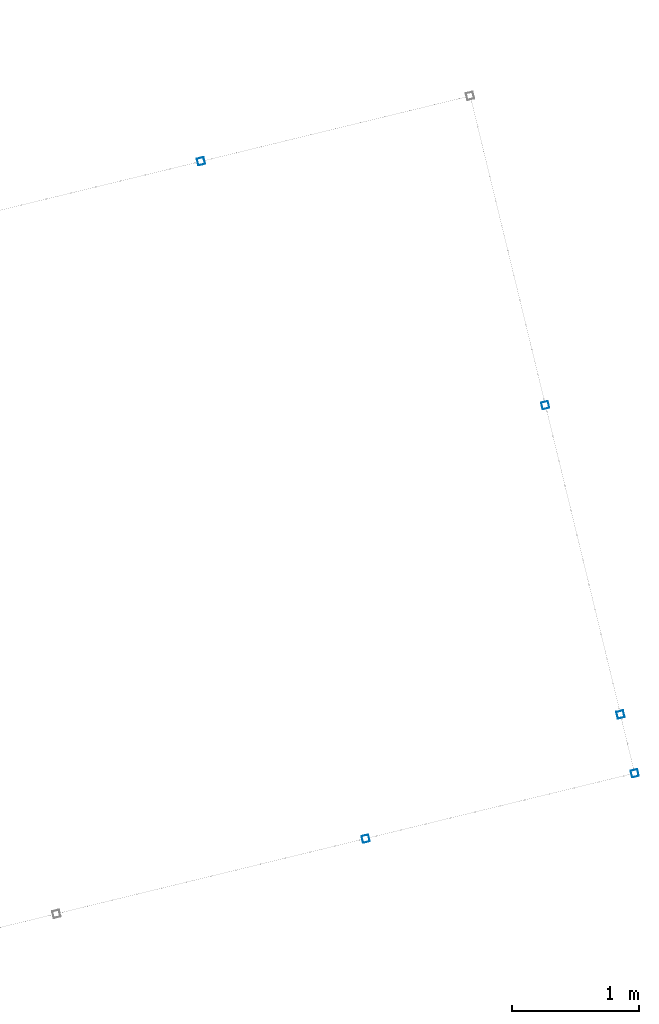
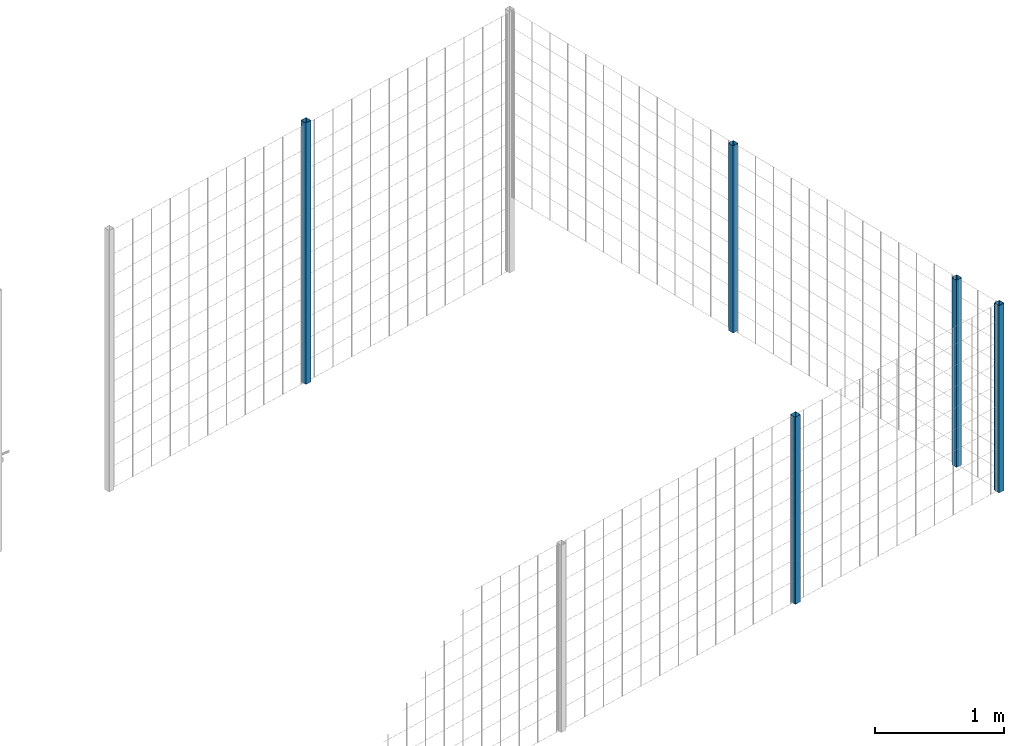
# One storey, part 4 of 10: 5 beams.
"""IFC2X3 building model written with IfcOpenShell, lengths in millimetres."""

from ifc_helpers import new_model, entity, si_unit, converted_unit, derived_unit, direction, frame, frame_2d, origin, place, context, subcontext, project, spatial, polyline, circle_curve, parameter, trimmed, segment, composite_curve, outline, extrude, material, type_object, element, save


model = new_model("IFC2X3")

# Units and contexts
model_context = context("Model", 3, precision=0.01, world=origin(), true_north=direction((6.12303176911189e-17, 1.0)))
body_context = subcontext(model_context, "Body", "Model", "MODEL_VIEW")
ifc_project = project(units=[si_unit("LENGTHUNIT", "METRE", prefix="MILLI"), si_unit("AREAUNIT", "SQUARE_METRE"), si_unit("VOLUMEUNIT", "CUBIC_METRE"), converted_unit("PLANEANGLEUNIT", "DEGREE", entity("IfcRatioMeasure", 0.0174532925199433), si_unit("PLANEANGLEUNIT", "RADIAN"), dimensions=[0, 0, 0, 0, 0, 0, 0]), si_unit("MASSUNIT", "GRAM", prefix="KILO"), derived_unit("MASSDENSITYUNIT", [(si_unit("MASSUNIT", "GRAM", prefix="KILO"), 1), (si_unit("LENGTHUNIT", "METRE"), -3)]), derived_unit("MOMENTOFINERTIAUNIT", [(si_unit("LENGTHUNIT", "METRE"), 4)]), si_unit("TIMEUNIT", "SECOND"), si_unit("FREQUENCYUNIT", "HERTZ"), si_unit("THERMODYNAMICTEMPERATUREUNIT", "DEGREE_CELSIUS"), derived_unit("THERMALTRANSMITTANCEUNIT", [(si_unit("MASSUNIT", "GRAM", prefix="KILO"), 1), (si_unit("THERMODYNAMICTEMPERATUREUNIT", "KELVIN"), -1), (si_unit("TIMEUNIT", "SECOND"), -3)]), derived_unit("VOLUMETRICFLOWRATEUNIT", [(si_unit("LENGTHUNIT", "METRE"), 3), (si_unit("TIMEUNIT", "SECOND"), -1)]), derived_unit("MASSFLOWRATEUNIT", [(si_unit("MASSUNIT", "GRAM", prefix="KILO"), 1), (si_unit("TIMEUNIT", "SECOND"), -1)]), derived_unit("ROTATIONALFREQUENCYUNIT", [(si_unit("TIMEUNIT", "SECOND"), -1)]), si_unit("ELECTRICCURRENTUNIT", "AMPERE"), si_unit("ELECTRICVOLTAGEUNIT", "VOLT"), si_unit("POWERUNIT", "WATT"), si_unit("FORCEUNIT", "NEWTON", prefix="KILO"), si_unit("ILLUMINANCEUNIT", "LUX"), si_unit("LUMINOUSFLUXUNIT", "LUMEN"), si_unit("LUMINOUSINTENSITYUNIT", "CANDELA"), derived_unit("USERDEFINED", [(si_unit("MASSUNIT", "GRAM", prefix="KILO"), -1), (si_unit("LENGTHUNIT", "METRE"), -2), (si_unit("TIMEUNIT", "SECOND"), 3), (si_unit("LUMINOUSFLUXUNIT", "LUMEN"), 1)]), derived_unit("LINEARVELOCITYUNIT", [(si_unit("LENGTHUNIT", "METRE"), 1), (si_unit("TIMEUNIT", "SECOND"), -1)]), si_unit("PRESSUREUNIT", "PASCAL"), derived_unit("USERDEFINED", [(si_unit("LENGTHUNIT", "METRE"), -2), (si_unit("MASSUNIT", "GRAM", prefix="KILO"), 1), (si_unit("TIMEUNIT", "SECOND"), -2)]), derived_unit("LINEARFORCEUNIT", [(si_unit("MASSUNIT", "GRAM", prefix="KILO"), 1), (si_unit("LENGTHUNIT", "METRE"), 1), (si_unit("TIMEUNIT", "SECOND"), -2), (si_unit("LENGTHUNIT", "METRE"), -1)]), derived_unit("PLANARFORCEUNIT", [(si_unit("MASSUNIT", "GRAM", prefix="KILO"), 1), (si_unit("LENGTHUNIT", "METRE"), 1), (si_unit("TIMEUNIT", "SECOND"), -2), (si_unit("LENGTHUNIT", "METRE"), -2)])], contexts=[model_context])

# Site, building, storey
site_placement = place(None, frame((19171.746869958, -72498.5768491146, 0.0), z_axis=(0.0, 0.0, 1.0), x_axis=(0.971695960795463, 0.236234967296933, 0.0)))
site = spatial("IfcSite", under=ifc_project, at=site_placement, CompositionType="ELEMENT")
building_placement = place(site_placement, origin())
building = spatial("IfcBuilding", under=site, at=building_placement, CompositionType="ELEMENT")
storey_placement = place(building_placement, origin())
storey = spatial("IfcBuildingStorey", under=building, at=storey_placement, CompositionType="ELEMENT", Elevation=0.0)

# Beams
ifc_material = material()
beam_type = type_object("IfcBeamType", PredefinedType="NOTDEFINED")
beam_1_placement = place(storey_placement, frame((7670.9047277641, 5570.90472776409, 0.0), z_axis=(1.0, 0.0, 0.0), x_axis=(0.0, 0.0, -1.0)))
element("IfcBeam", 1, at=beam_1_placement, inside=storey, type_object=beam_type, material=ifc_material, context=body_context, shape_type="SweptSolid", body=[
    extrude(outline(composite_curve([segment(trimmed(circle_curve(frame_2d((24.6999999999997, -24.6999999999999), x_axis=(1.0, 0.0)), 2.79999999999974), [parameter(269.999999999999)], [parameter(1.32311074748882e-12)], True, "PARAMETER"), True, "CONTINUOUS"), segment(polyline([(27.4999999999991, -24.6999999999988), (27.4999999999981, 24.7000000000008)]), True, "CONTINUOUS"), segment(trimmed(circle_curve(frame_2d((24.6999999999999, 24.7000000000008), x_axis=(1.0, 0.0)), 2.79999999999845), [parameter(1.32311074748882e-12)], [parameter(90.0000000000001)], True, "PARAMETER"), True, "CONTINUOUS"), segment(polyline([(24.6999999999999, 27.4999999999991), (-24.6999999999997, 27.4999999999992)]), True, "CONTINUOUS"), segment(trimmed(circle_curve(frame_2d((-24.6999999999997, 24.7000000000009), x_axis=(1.0, 0.0)), 2.79999999999845), [parameter(90.0000000000001)], [parameter(180.0)], True, "PARAMETER"), True, "CONTINUOUS"), segment(polyline([(-27.499999999998, 24.7000000000009), (-27.4999999999981, -24.6999999999997)]), True, "CONTINUOUS"), segment(trimmed(circle_curve(frame_2d((-24.6999999999999, -24.6999999999997), x_axis=(1.0, 0.0)), 2.79999999999845), [parameter(180.0)], [parameter(269.999999999998)], True, "PARAMETER"), True, "CONTINUOUS"), segment(polyline([(-24.6999999999999, -27.499999999998), (24.6999999999997, -27.4999999999992)]), True, "CONTINUOUS")], self_intersect=False), holes=[composite_curve([segment(polyline([(23.3000000000001, -26.0999999999995), (-23.3000000000002, -26.0999999999994)]), True, "CONTINUOUS"), segment(trimmed(circle_curve(frame_2d((-23.3000000000002, -23.299999999999), x_axis=(1.0, 0.0)), 2.79999999999973), [parameter(180.0)], [parameter(270.0)], True, "PARAMETER"), False, "CONTINUOUS"), segment(polyline([(-26.1000000000006, -23.299999999999), (-26.1000000000005, 23.3000000000013)]), True, "CONTINUOUS"), segment(trimmed(circle_curve(frame_2d((-23.3000000000001, 23.3000000000013), x_axis=(1.0, 0.0)), 2.79999999999973), [parameter(90.0000000000004)], [parameter(180.0)], True, "PARAMETER"), False, "CONTINUOUS"), segment(polyline([(-23.3000000000001, 26.1000000000006), (23.2999999999991, 26.1000000000005)]), True, "CONTINUOUS"), segment(trimmed(circle_curve(frame_2d((23.2999999999991, 23.3000000000011), x_axis=(1.0, 0.0)), 2.79999999999973), [parameter(3.56222124323914e-13)], [parameter(90.0000000000004)], True, "PARAMETER"), False, "CONTINUOUS"), segment(polyline([(26.0999999999995, 23.3000000000011), (26.0999999999994, -23.2999999999991)]), True, "CONTINUOUS"), segment(trimmed(circle_curve(frame_2d((23.299999999999, -23.2999999999991), x_axis=(1.0, 0.0)), 2.80000000000034), [parameter(270.0)], [parameter(4.57999874130747e-13)], True, "PARAMETER"), False, "CONTINUOUS")], self_intersect=False)]), frame((-2465.97922445826, 29.095272235914, 29.095272235914), z_axis=(1.0, 0.0, 0.0), x_axis=(0.0, 1.0, 0.0)), (0.0, 0.0, 1.0), 2465.97922445826),
])
beam_2_placement = place(storey_placement, frame((9845.90472776407, 3070.90472776409, 700.0), z_axis=(1.0, 0.0, 0.0), x_axis=(0.0, 0.0, 1.0)))
element("IfcBeam", 2, at=beam_2_placement, inside=storey, type_object=beam_type, material=ifc_material, context=body_context, shape_type="SweptSolid", body=[
    extrude(outline(composite_curve([segment(trimmed(circle_curve(frame_2d((24.6999999999999, -24.7000000000008), x_axis=(1.0, 0.0)), 2.79999999999974), [parameter(269.999999999999)], [parameter(1.32311074748882e-12)], True, "PARAMETER"), True, "CONTINUOUS"), segment(polyline([(27.4999999999998, -24.7000000000008), (27.4999999999986, 24.6999999999988)]), True, "CONTINUOUS"), segment(trimmed(circle_curve(frame_2d((24.6999999999997, 24.6999999999988), x_axis=(1.0, 0.0)), 2.79999999999845), [parameter(1.32311074748882e-12)], [parameter(90.0000000000001)], True, "PARAMETER"), True, "CONTINUOUS"), segment(polyline([(24.6999999999997, 27.4999999999981), (-24.6999999999999, 27.499999999998)]), True, "CONTINUOUS"), segment(trimmed(circle_curve(frame_2d((-24.7000000000004, 24.6999999999987), x_axis=(1.0, 0.0)), 2.79999999999845), [parameter(90.0000000000001)], [parameter(180.0)], True, "PARAMETER"), True, "CONTINUOUS"), segment(polyline([(-27.4999999999987, 24.6999999999986), (-27.4999999999986, -24.700000000001)]), True, "CONTINUOUS"), segment(trimmed(circle_curve(frame_2d((-24.7000000000003, -24.7000000000009), x_axis=(1.0, 0.0)), 2.79999999999845), [parameter(180.0)], [parameter(269.999999999998)], True, "PARAMETER"), True, "CONTINUOUS"), segment(polyline([(-24.7000000000003, -27.4999999999981), (24.6999999999999, -27.5000000000002)]), True, "CONTINUOUS")], self_intersect=False), holes=[composite_curve([segment(polyline([(23.2999999999996, -26.1000000000005), (-23.3000000000006, -26.1000000000006)]), True, "CONTINUOUS"), segment(trimmed(circle_curve(frame_2d((-23.3000000000006, -23.3000000000013), x_axis=(1.0, 0.0)), 2.79999999999973), [parameter(180.0)], [parameter(270.0)], True, "PARAMETER"), False, "CONTINUOUS"), segment(polyline([(-26.1, -23.3000000000013), (-26.1000000000001, 23.299999999999)]), True, "CONTINUOUS"), segment(trimmed(circle_curve(frame_2d((-23.3000000000007, 23.299999999999), x_axis=(1.0, 0.0)), 2.79999999999973), [parameter(90.0000000000004)], [parameter(180.0)], True, "PARAMETER"), False, "CONTINUOUS"), segment(polyline([(-23.3000000000002, 26.0999999999983), (23.2999999999995, 26.0999999999985)]), True, "CONTINUOUS"), segment(trimmed(circle_curve(frame_2d((23.2999999999995, 23.2999999999991), x_axis=(1.0, 0.0)), 2.79999999999973), [parameter(3.56222124323914e-13)], [parameter(90.0000000000004)], True, "PARAMETER"), False, "CONTINUOUS"), segment(polyline([(26.0999999999994, 23.2999999999991), (26.1000000000001, -23.3000000000011)]), True, "CONTINUOUS"), segment(trimmed(circle_curve(frame_2d((23.2999999999996, -23.3000000000011), x_axis=(1.0, 0.0)), 2.80000000000034), [parameter(270.0)], [parameter(4.57999874130747e-13)], True, "PARAMETER"), False, "CONTINUOUS")], self_intersect=False)]), frame((0.0, -29.0952722359145, 29.0952722359118), z_axis=(1.0, 0.0, 0.0), x_axis=(0.0, -1.0, 0.0)), (0.0, 0.0, 1.0), 1765.0),
])
beam_3_placement = place(storey_placement, frame((9845.90472776407, 570.904727764087, 699.02077554174), z_axis=(1.0, 0.0, 0.0), x_axis=(0.0, 0.0, 1.0)))
element("IfcBeam", 3, at=beam_3_placement, inside=storey, type_object=beam_type, material=ifc_material, context=body_context, shape_type="SweptSolid", body=[
    extrude(outline(composite_curve([segment(trimmed(circle_curve(frame_2d((24.6999999999999, -24.7000000000008), x_axis=(1.0, 0.0)), 2.79999999999974), [parameter(269.999999999999)], [parameter(1.32311074748882e-12)], True, "PARAMETER"), True, "CONTINUOUS"), segment(polyline([(27.4999999999996, -24.7000000000008), (27.4999999999983, 24.6999999999988)]), True, "CONTINUOUS"), segment(trimmed(circle_curve(frame_2d((24.6999999999997, 24.6999999999988), x_axis=(1.0, 0.0)), 2.79999999999845), [parameter(1.32311074748882e-12)], [parameter(90.0000000000001)], True, "PARAMETER"), True, "CONTINUOUS"), segment(polyline([(24.6999999999999, 27.4999999999981), (-24.7000000000002, 27.499999999998)]), True, "CONTINUOUS"), segment(trimmed(circle_curve(frame_2d((-24.7000000000002, 24.6999999999987), x_axis=(1.0, 0.0)), 2.79999999999845), [parameter(90.0000000000001)], [parameter(180.0)], True, "PARAMETER"), True, "CONTINUOUS"), segment(polyline([(-27.4999999999986, 24.6999999999986), (-27.4999999999986, -24.700000000001)]), True, "CONTINUOUS"), segment(trimmed(circle_curve(frame_2d((-24.7000000000002, -24.7000000000009), x_axis=(1.0, 0.0)), 2.79999999999845), [parameter(180.0)], [parameter(269.999999999998)], True, "PARAMETER"), True, "CONTINUOUS"), segment(polyline([(-24.7000000000001, -27.4999999999981), (24.6999999999999, -27.5000000000002)]), True, "CONTINUOUS")], self_intersect=False), holes=[composite_curve([segment(polyline([(23.2999999999995, -26.1000000000005), (-23.3000000000005, -26.1000000000006)]), True, "CONTINUOUS"), segment(trimmed(circle_curve(frame_2d((-23.3000000000005, -23.3000000000013), x_axis=(1.0, 0.0)), 2.79999999999973), [parameter(180.0)], [parameter(270.0)], True, "PARAMETER"), False, "CONTINUOUS"), segment(polyline([(-26.1000000000002, -23.3000000000013), (-26.1000000000002, 23.299999999999)]), True, "CONTINUOUS"), segment(trimmed(circle_curve(frame_2d((-23.3000000000005, 23.299999999999), x_axis=(1.0, 0.0)), 2.79999999999973), [parameter(90.0000000000004)], [parameter(180.0)], True, "PARAMETER"), False, "CONTINUOUS"), segment(polyline([(-23.3000000000005, 26.0999999999983), (23.2999999999995, 26.0999999999985)]), True, "CONTINUOUS"), segment(trimmed(circle_curve(frame_2d((23.2999999999994, 23.2999999999991), x_axis=(1.0, 0.0)), 2.79999999999973), [parameter(3.56222124323914e-13)], [parameter(90.0000000000004)], True, "PARAMETER"), False, "CONTINUOUS"), segment(polyline([(26.0999999999993, 23.2999999999991), (26.0999999999998, -23.3000000000011)]), True, "CONTINUOUS"), segment(trimmed(circle_curve(frame_2d((23.2999999999995, -23.3000000000011), x_axis=(1.0, 0.0)), 2.80000000000034), [parameter(270.0)], [parameter(4.57999874130747e-13)], True, "PARAMETER"), False, "CONTINUOUS")], self_intersect=False)]), frame((0.0, -29.0952722359147, 29.0952722359118), z_axis=(1.0, 0.0, 0.0), x_axis=(0.0, -1.0, 0.0)), (0.0, 0.0, 1.0), 1765.97922445826),
])
beam_4_placement = place(storey_placement, frame((9845.90472776407, 95.9047277640865, 699.02077554174), z_axis=(1.0, 0.0, 0.0), x_axis=(0.0, 0.0, 1.0)))
element("IfcBeam", 4, at=beam_4_placement, inside=storey, type_object=beam_type, material=ifc_material, context=body_context, shape_type="SweptSolid", body=[
    extrude(outline(composite_curve([segment(trimmed(circle_curve(frame_2d((24.6999999999999, -24.7000000000008), x_axis=(1.0, 0.0)), 2.79999999999974), [parameter(269.999999999999)], [parameter(1.32311074748882e-12)], True, "PARAMETER"), True, "CONTINUOUS"), segment(polyline([(27.4999999999996, -24.7000000000008), (27.4999999999983, 24.6999999999988)]), True, "CONTINUOUS"), segment(trimmed(circle_curve(frame_2d((24.6999999999998, 24.6999999999988), x_axis=(1.0, 0.0)), 2.79999999999845), [parameter(1.32311074748882e-12)], [parameter(90.0000000000001)], True, "PARAMETER"), True, "CONTINUOUS"), segment(polyline([(24.6999999999999, 27.4999999999981), (-24.7000000000002, 27.499999999998)]), True, "CONTINUOUS"), segment(trimmed(circle_curve(frame_2d((-24.7000000000002, 24.6999999999987), x_axis=(1.0, 0.0)), 2.79999999999845), [parameter(90.0000000000001)], [parameter(180.0)], True, "PARAMETER"), True, "CONTINUOUS"), segment(polyline([(-27.4999999999986, 24.6999999999986), (-27.4999999999986, -24.700000000001)]), True, "CONTINUOUS"), segment(trimmed(circle_curve(frame_2d((-24.7000000000001, -24.7000000000009), x_axis=(1.0, 0.0)), 2.79999999999845), [parameter(180.0)], [parameter(269.999999999998)], True, "PARAMETER"), True, "CONTINUOUS"), segment(polyline([(-24.7000000000002, -27.4999999999981), (24.6999999999999, -27.5000000000002)]), True, "CONTINUOUS")], self_intersect=False), holes=[composite_curve([segment(polyline([(23.2999999999995, -26.1000000000005), (-23.3000000000005, -26.1000000000006)]), True, "CONTINUOUS"), segment(trimmed(circle_curve(frame_2d((-23.3000000000005, -23.3000000000013), x_axis=(1.0, 0.0)), 2.79999999999973), [parameter(180.0)], [parameter(270.0)], True, "PARAMETER"), False, "CONTINUOUS"), segment(polyline([(-26.1000000000002, -23.3000000000013), (-26.1000000000002, 23.299999999999)]), True, "CONTINUOUS"), segment(trimmed(circle_curve(frame_2d((-23.3000000000005, 23.299999999999), x_axis=(1.0, 0.0)), 2.79999999999973), [parameter(90.0000000000004)], [parameter(180.0)], True, "PARAMETER"), False, "CONTINUOUS"), segment(polyline([(-23.3000000000005, 26.0999999999983), (23.2999999999995, 26.0999999999985)]), True, "CONTINUOUS"), segment(trimmed(circle_curve(frame_2d((23.2999999999995, 23.2999999999991), x_axis=(1.0, 0.0)), 2.79999999999973), [parameter(3.56222124323914e-13)], [parameter(90.0000000000004)], True, "PARAMETER"), False, "CONTINUOUS"), segment(polyline([(26.0999999999992, 23.2999999999991), (26.0999999999999, -23.3000000000011)]), True, "CONTINUOUS"), segment(trimmed(circle_curve(frame_2d((23.2999999999995, -23.3000000000011), x_axis=(1.0, 0.0)), 2.80000000000034), [parameter(270.0)], [parameter(4.57999874130747e-13)], True, "PARAMETER"), False, "CONTINUOUS")], self_intersect=False)]), frame((0.0, -29.0952722359147, 29.0952722359118), z_axis=(1.0, 0.0, 0.0), x_axis=(0.0, -1.0, 0.0)), (0.0, 0.0, 1.0), 1765.97922445826),
])
beam_5_placement = place(storey_placement, frame((7671.13018912596, 95.9047277640865, 699.02077554174), z_axis=(1.0, 0.0, 0.0), x_axis=(0.0, 0.0, 1.0)))
element("IfcBeam", 5, at=beam_5_placement, inside=storey, type_object=beam_type, material=ifc_material, context=body_context, shape_type="SweptSolid", body=[
    extrude(outline(composite_curve([segment(trimmed(circle_curve(frame_2d((24.6999999999999, -24.6999999999997), x_axis=(1.0, 0.0)), 2.79999999999974), [parameter(269.999999999999)], [parameter(1.32311074748882e-12)], True, "PARAMETER"), True, "CONTINUOUS"), segment(polyline([(27.4999999999996, -24.6999999999997), (27.4999999999983, 24.7000000000009)]), True, "CONTINUOUS"), segment(trimmed(circle_curve(frame_2d((24.6999999999998, 24.7000000000009), x_axis=(1.0, 0.0)), 2.79999999999845), [parameter(1.32311074748882e-12)], [parameter(90.0000000000001)], True, "PARAMETER"), True, "CONTINUOUS"), segment(polyline([(24.6999999999999, 27.4999999999992), (-24.7000000000002, 27.4999999999991)]), True, "CONTINUOUS"), segment(trimmed(circle_curve(frame_2d((-24.7000000000002, 24.7000000000008), x_axis=(1.0, 0.0)), 2.79999999999845), [parameter(90.0000000000001)], [parameter(180.0)], True, "PARAMETER"), True, "CONTINUOUS"), segment(polyline([(-27.4999999999986, 24.7000000000008), (-27.4999999999986, -24.6999999999988)]), True, "CONTINUOUS"), segment(trimmed(circle_curve(frame_2d((-24.7000000000001, -24.6999999999999), x_axis=(1.0, 0.0)), 2.79999999999845), [parameter(180.0)], [parameter(269.999999999998)], True, "PARAMETER"), True, "CONTINUOUS"), segment(polyline([(-24.7000000000002, -27.4999999999981), (24.6999999999999, -27.4999999999991)]), True, "CONTINUOUS")], self_intersect=False), holes=[composite_curve([segment(polyline([(23.2999999999995, -26.0999999999994), (-23.3000000000005, -26.0999999999985)]), True, "CONTINUOUS"), segment(trimmed(circle_curve(frame_2d((-23.3000000000005, -23.2999999999991), x_axis=(1.0, 0.0)), 2.79999999999973), [parameter(180.0)], [parameter(270.0)], True, "PARAMETER"), False, "CONTINUOUS"), segment(polyline([(-26.1000000000002, -23.2999999999991), (-26.1000000000002, 23.3000000000011)]), True, "CONTINUOUS"), segment(trimmed(circle_curve(frame_2d((-23.3000000000005, 23.3000000000011), x_axis=(1.0, 0.0)), 2.79999999999973), [parameter(90.0000000000004)], [parameter(180.0)], True, "PARAMETER"), False, "CONTINUOUS"), segment(polyline([(-23.3000000000005, 26.1000000000005), (23.2999999999995, 26.1000000000006)]), True, "CONTINUOUS"), segment(trimmed(circle_curve(frame_2d((23.2999999999995, 23.3000000000013), x_axis=(1.0, 0.0)), 2.79999999999973), [parameter(3.56222124323914e-13)], [parameter(90.0000000000004)], True, "PARAMETER"), False, "CONTINUOUS"), segment(polyline([(26.0999999999992, 23.3000000000013), (26.0999999999999, -23.299999999999)]), True, "CONTINUOUS"), segment(trimmed(circle_curve(frame_2d((23.2999999999995, -23.299999999999), x_axis=(1.0, 0.0)), 2.80000000000034), [parameter(270.0)], [parameter(4.57999874130747e-13)], True, "PARAMETER"), False, "CONTINUOUS")], self_intersect=False)]), frame((0.0, -29.0952722359147, 29.0952722359151), z_axis=(1.0, 0.0, 0.0), x_axis=(0.0, -1.0, 0.0)), (0.0, 0.0, 1.0), 1765.97922445826),
])

save(model, "model.ifc")
